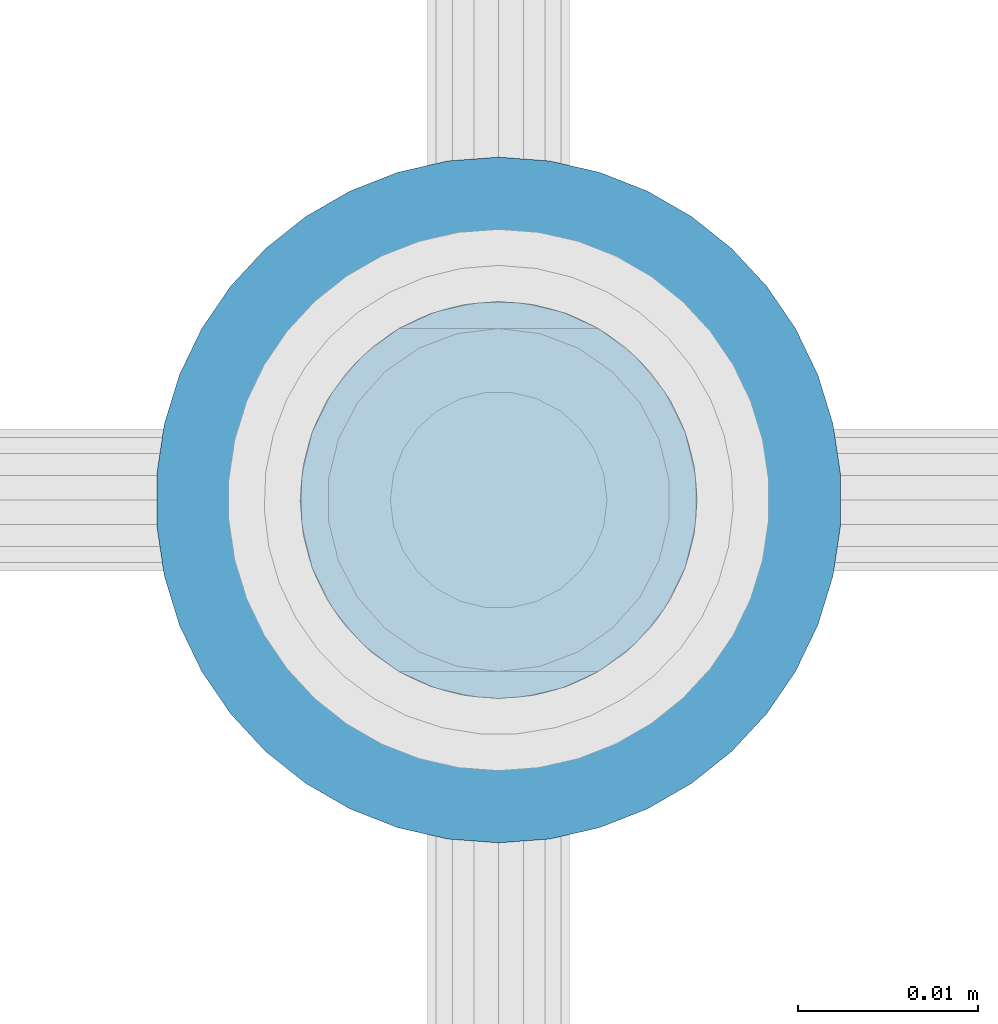
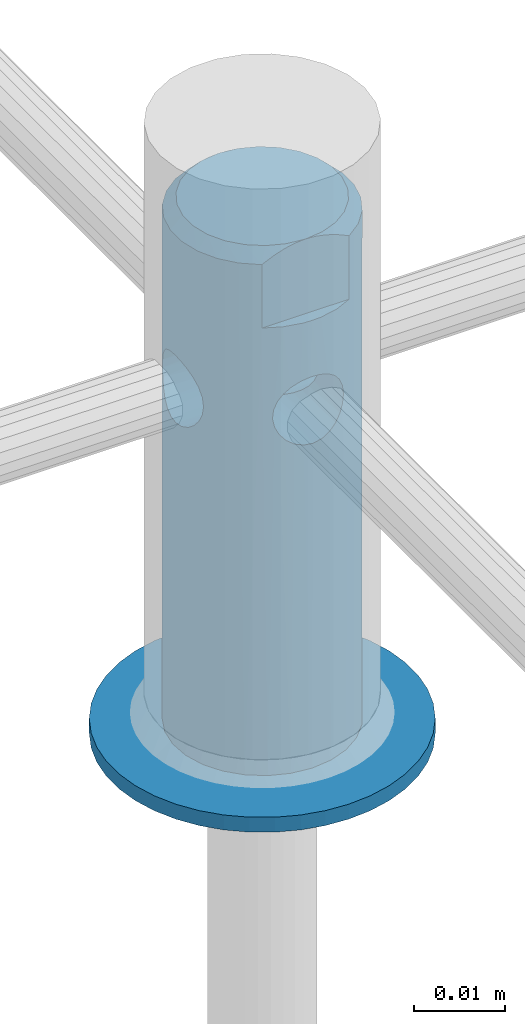
# One storey, part 2 of 3: 2 members.
"""IFC4 building model written with IfcOpenShell, lengths in metres."""

from ifc_helpers import new_model, si_unit, direction, frame, origin_with_axes, place, context, subcontext, project, spatial, triangles, material, element, save


model = new_model("IFC4")

# Units and contexts
model_context = context("Model", 3, precision=1e-05, world=origin_with_axes(), true_north=direction((0.0, 1.0)))
body_context = subcontext(model_context, "Body", "Model", "MODEL_VIEW")
ifc_project = project(units=[si_unit("LENGTHUNIT", "METRE"), si_unit("PLANEANGLEUNIT", "RADIAN"), si_unit("MASSUNIT", "GRAM", prefix="KILO"), si_unit("AREAUNIT", "SQUARE_METRE"), si_unit("TIMEUNIT", "SECOND"), si_unit("VOLUMEUNIT", "CUBIC_METRE")], contexts=[model_context])

# Site, building, storey
site_placement = place(None, origin_with_axes())
site = spatial("IfcSite", under=ifc_project, at=site_placement, CompositionType="ELEMENT")
building_placement = place(site_placement, origin_with_axes())
building = spatial("IfcBuilding", under=site, at=building_placement, CompositionType="ELEMENT")
storey_placement = place(building_placement, origin_with_axes())
storey = spatial("IfcBuildingStorey", under=building, at=storey_placement, Name="Geschoss 1", CompositionType="ELEMENT", Elevation=0.0)

# Members
ifc_material = material()
member_1_placement = place(storey_placement, frame((8.149333, 6.0175, 0.018), z_axis=(0.0, 1.0, 0.0), x_axis=(0.0, 0.0, 1.0)))
element("IfcMember", 1, at=member_1_placement, inside=storey, material=ifc_material, PredefinedType="STUD", context=body_context, shape_type="Tessellation", body=[
    triangles([(0.002, -0.010703, -0.015699), (0.002, -0.008244, -0.017118), (0.002, -0.003688, -0.007658), (0.002, -0.0056, -0.018156), (0.002, -0.001891, -0.008287), (0.002, -0.002832, -0.018788), (0.002, 0.0, -0.0085), (0.002, 0.0, -0.019), (0.002, 0.002832, -0.018788), (0.002, -0.0053, -0.006646), (0.002, -0.012923, -0.013928), (0.002, -0.006646, -0.0053), (0.002, -0.014855, -0.011846), (0.002, -0.016454, -0.0095), (0.002, -0.007658, -0.003688), (0.002, -0.017687, -0.006941), (0.002, -0.008287, -0.001891), (0.002, -0.018524, -0.004228), (0.002, -0.018947, -0.00142), (0.002, -0.0085, 0.0), (0.002, -0.018947, 0.00142), (0.002, -0.008287, 0.001891), (0.002, -0.018524, 0.004228), (0.002, -0.017687, 0.006941), (0.002, -0.007658, 0.003688), (0.002, -0.016454, 0.0095), (0.002, -0.006646, 0.0053), (0.002, -0.014855, 0.011846), (0.002, -0.012923, 0.013928), (0.002, -0.0053, 0.006646), (0.002, -0.010703, 0.015699), (0.002, -0.003688, 0.007658), (0.002, -0.008244, 0.017118), (0.002, -0.0056, 0.018156), (0.002, -0.001891, 0.008287), (0.002, -0.002832, 0.018788), (0.002, 0.0, 0.0085), (0.002, 0.0, 0.019), (0.002, 0.002832, 0.018788), (0.002, 0.001891, 0.008287), (0.002, 0.0056, 0.018156), (0.002, 0.003688, 0.007658), (0.002, 0.008244, 0.017118), (0.002, 0.010703, 0.015699), (0.002, 0.0053, 0.006646), (0.002, 0.012923, 0.013928), (0.002, 0.006646, 0.0053), (0.002, 0.014855, 0.011846), (0.002, 0.016454, 0.0095), (0.002, 0.007658, 0.003688), (0.002, 0.017687, 0.006941), (0.002, 0.008287, 0.001891), (0.002, 0.018524, 0.004228), (0.002, 0.018947, 0.00142), (0.002, 0.0085, 0.0), (0.002, 0.018947, -0.00142), (0.002, 0.008287, -0.001891), (0.002, 0.018524, -0.004228), (0.002, 0.017687, -0.006941), (0.002, 0.007658, -0.003688), (0.002, 0.016454, -0.0095), (0.002, 0.006646, -0.0053), (0.002, 0.014855, -0.011846), (0.002, 0.012923, -0.013928), (0.002, 0.0053, -0.006646), (0.002, 0.010703, -0.015699), (0.002, 0.003688, -0.007658), (0.002, 0.008244, -0.017118), (0.002, 0.0056, -0.018156), (0.002, 0.001891, -0.008287), (0.0, 0.010703, -0.015699), (0.0, 0.008244, -0.017118), (0.0, 0.003688, -0.007658), (0.0, 0.0056, -0.018156), (0.0, 0.001891, -0.008287), (0.0, 0.002832, -0.018788), (0.0, 0.0, -0.0085), (0.0, 0.0, -0.019), (0.0, -0.002832, -0.018788), (0.0, 0.0053, -0.006646), (0.0, 0.012923, -0.013928), (0.0, 0.006646, -0.0053), (0.0, 0.014855, -0.011846), (0.0, 0.016454, -0.0095), (0.0, 0.007658, -0.003688), (0.0, 0.017687, -0.006941), (0.0, 0.008287, -0.001891), (0.0, 0.018524, -0.004228), (0.0, 0.018947, -0.00142), (0.0, 0.0085, 0.0), (0.0, 0.018947, 0.00142), (0.0, 0.008287, 0.001891), (0.0, 0.018524, 0.004228), (0.0, 0.017687, 0.006941), (0.0, 0.007658, 0.003688), (0.0, 0.016454, 0.0095), (0.0, 0.006646, 0.0053), (0.0, 0.014855, 0.011846), (0.0, 0.012923, 0.013928), (0.0, 0.0053, 0.006646), (0.0, 0.010703, 0.015699), (0.0, 0.003688, 0.007658), (0.0, 0.008244, 0.017118), (0.0, 0.0056, 0.018156), (0.0, 0.001891, 0.008287), (0.0, 0.002832, 0.018788), (0.0, 0.0, 0.0085), (0.0, 0.0, 0.019), (0.0, -0.002832, 0.018788), (0.0, -0.001891, 0.008287), (0.0, -0.0056, 0.018156), (0.0, -0.003688, 0.007658), (0.0, -0.008244, 0.017118), (0.0, -0.010703, 0.015699), (0.0, -0.0053, 0.006646), (0.0, -0.012923, 0.013928), (0.0, -0.006646, 0.0053), (0.0, -0.014855, 0.011846), (0.0, -0.016454, 0.0095), (0.0, -0.007658, 0.003688), (0.0, -0.017687, 0.006941), (0.0, -0.008287, 0.001891), (0.0, -0.018524, 0.004228), (0.0, -0.018947, 0.00142), (0.0, -0.0085, 0.0), (0.0, -0.018947, -0.00142), (0.0, -0.008287, -0.001891), (0.0, -0.018524, -0.004228), (0.0, -0.017687, -0.006941), (0.0, -0.007658, -0.003688), (0.0, -0.016454, -0.0095), (0.0, -0.006646, -0.0053), (0.0, -0.014855, -0.011846), (0.0, -0.012923, -0.013928), (0.0, -0.0053, -0.006646), (0.0, -0.010703, -0.015699), (0.0, -0.003688, -0.007658), (0.0, -0.008244, -0.017118), (0.0, -0.0056, -0.018156), (0.0, -0.001891, -0.008287)], [[1, 2, 3], [3, 2, 4], [3, 4, 5], [5, 4, 6], [5, 6, 7], [7, 6, 8], [7, 8, 9], [3, 10, 1], [1, 10, 11], [10, 12, 11], [11, 12, 13], [13, 12, 14], [14, 12, 15], [14, 15, 16], [16, 15, 17], [16, 17, 18], [18, 17, 19], [17, 20, 19], [19, 20, 21], [20, 22, 21], [21, 22, 23], [23, 22, 24], [24, 22, 25], [24, 25, 26], [26, 25, 27], [26, 27, 28], [28, 27, 29], [27, 30, 29], [29, 30, 31], [30, 32, 31], [31, 32, 33], [33, 32, 34], [34, 32, 35], [34, 35, 36], [36, 35, 37], [36, 37, 38], [38, 37, 39], [37, 40, 39], [39, 40, 41], [40, 42, 41], [41, 42, 43], [43, 42, 44], [44, 42, 45], [44, 45, 46], [46, 45, 47], [46, 47, 48], [48, 47, 49], [47, 50, 49], [49, 50, 51], [50, 52, 51], [51, 52, 53], [53, 52, 54], [54, 52, 55], [54, 55, 56], [56, 55, 57], [56, 57, 58], [58, 57, 59], [57, 60, 59], [59, 60, 61], [60, 62, 61], [61, 62, 63], [63, 62, 64], [64, 62, 65], [64, 65, 66], [66, 65, 67], [66, 67, 68], [68, 67, 69], [67, 70, 69], [69, 70, 9], [70, 7, 9], [71, 72, 73], [73, 72, 74], [73, 74, 75], [75, 74, 76], [75, 76, 77], [77, 76, 78], [77, 78, 79], [73, 80, 71], [71, 80, 81], [80, 82, 81], [81, 82, 83], [83, 82, 84], [84, 82, 85], [84, 85, 86], [86, 85, 87], [86, 87, 88], [88, 87, 89], [87, 90, 89], [89, 90, 91], [90, 92, 91], [91, 92, 93], [93, 92, 94], [94, 92, 95], [94, 95, 96], [96, 95, 97], [96, 97, 98], [98, 97, 99], [97, 100, 99], [99, 100, 101], [100, 102, 101], [101, 102, 103], [103, 102, 104], [104, 102, 105], [104, 105, 106], [106, 105, 107], [106, 107, 108], [108, 107, 109], [107, 110, 109], [109, 110, 111], [110, 112, 111], [111, 112, 113], [113, 112, 114], [114, 112, 115], [114, 115, 116], [116, 115, 117], [116, 117, 118], [118, 117, 119], [117, 120, 119], [119, 120, 121], [120, 122, 121], [121, 122, 123], [123, 122, 124], [124, 122, 125], [124, 125, 126], [126, 125, 127], [126, 127, 128], [128, 127, 129], [127, 130, 129], [129, 130, 131], [130, 132, 131], [131, 132, 133], [133, 132, 134], [134, 132, 135], [134, 135, 136], [136, 135, 137], [136, 137, 138], [138, 137, 139], [137, 140, 139], [139, 140, 79], [140, 77, 79], [70, 77, 7], [7, 77, 140], [7, 140, 5], [5, 140, 137], [5, 137, 3], [3, 137, 135], [3, 135, 10], [10, 135, 132], [10, 132, 12], [12, 132, 130], [12, 130, 15], [15, 130, 127], [15, 127, 17], [17, 127, 125], [17, 125, 20], [20, 125, 122], [20, 122, 22], [22, 122, 120], [22, 120, 25], [25, 120, 117], [25, 117, 27], [27, 117, 115], [27, 115, 30], [30, 115, 112], [30, 112, 32], [32, 112, 110], [32, 110, 35], [35, 110, 107], [35, 107, 37], [37, 107, 105], [37, 105, 40], [40, 105, 102], [40, 102, 42], [42, 102, 100], [42, 100, 45], [45, 100, 97], [45, 97, 47], [47, 97, 95], [47, 95, 50], [50, 95, 92], [50, 92, 52], [52, 92, 90], [52, 90, 55], [55, 90, 87], [55, 87, 57], [57, 87, 85], [57, 85, 60], [60, 85, 82], [60, 82, 62], [62, 82, 80], [62, 80, 65], [65, 80, 73], [65, 73, 67], [67, 73, 75], [67, 75, 70], [70, 75, 77], [76, 8, 78], [78, 8, 6], [78, 6, 79], [79, 6, 4], [79, 4, 139], [139, 4, 2], [139, 2, 138], [138, 2, 1], [138, 1, 136], [136, 1, 11], [136, 11, 134], [134, 11, 13], [134, 13, 133], [133, 13, 14], [133, 14, 131], [131, 14, 16], [131, 16, 129], [129, 16, 18], [129, 18, 128], [128, 18, 19], [128, 19, 126], [126, 19, 21], [126, 21, 124], [124, 21, 23], [124, 23, 123], [123, 23, 24], [123, 24, 121], [121, 24, 26], [121, 26, 119], [119, 26, 28], [119, 28, 118], [118, 28, 29], [118, 29, 116], [116, 29, 31], [116, 31, 114], [114, 31, 33], [114, 33, 113], [113, 33, 34], [113, 34, 111], [111, 34, 36], [111, 36, 109], [109, 36, 38], [109, 38, 108], [108, 38, 39], [108, 39, 106], [106, 39, 41], [106, 41, 104], [104, 41, 43], [104, 43, 103], [103, 43, 44], [103, 44, 101], [101, 44, 46], [101, 46, 99], [99, 46, 48], [99, 48, 98], [98, 48, 49], [98, 49, 96], [96, 49, 51], [96, 51, 94], [94, 51, 53], [94, 53, 93], [93, 53, 54], [93, 54, 91], [91, 54, 56], [91, 56, 89], [89, 56, 58], [89, 58, 88], [88, 58, 59], [88, 59, 86], [86, 59, 61], [86, 61, 84], [84, 61, 63], [84, 63, 83], [83, 63, 64], [83, 64, 81], [81, 64, 66], [81, 66, 71], [71, 66, 68], [71, 68, 72], [72, 68, 69], [72, 69, 74], [74, 69, 9], [74, 9, 76], [76, 9, 8]], closed=True),
])
member_2_placement = place(storey_placement, frame((8.149333, 6.0175, 0.02), z_axis=(0.0, 1.0, 0.0), x_axis=(0.0, 0.0, 1.0)))
element("IfcMember", 2, at=member_2_placement, inside=storey, material=ifc_material, PredefinedType="STUD", context=body_context, shape_type="Tessellation", body=[
    triangles([(0.043586, -0.000878, 0.000878), (0.043625, -0.010949, 0.001048), (0.0435, 0.0, 0.0), (0.043501, -0.011, -9.9e-05), (0.043653, -0.001165, -0.001165), (0.043677, -0.010928, -0.001247), (0.044103, -0.00225, -0.00225), (0.044148, -0.010751, -0.002325), (0.044818, -0.003182, -0.003182), (0.044854, -0.010519, -0.003217), (0.04575, -0.003897, -0.003897), (0.045765, -0.010283, -0.003905), (0.046853, -0.010104, -0.00435), (0.043843, -0.001722, 0.001722), (0.044046, -0.010788, 0.002148), (0.044258, -0.0025, 0.0025), (0.044718, -0.01056, 0.003079), (0.044818, -0.003182, 0.003182), (0.0455, -0.003742, 0.003742), (0.045591, -0.010322, 0.0038), (0.046278, -0.004157, 0.004157), (0.046655, -0.010128, 0.004294), (0.047122, -0.004414, 0.004414), (0.047802, -0.01004, 0.004495), (0.048, -0.0045, 0.0045), (0.048587, -0.004462, 0.004462), (0.048947, -0.010083, 0.004398), (0.049165, -0.004347, 0.004347), (0.050055, -0.010246, 0.004003), (0.05025, -0.003897, 0.003897), (0.051004, -0.010477, 0.00335), (0.051182, -0.003182, 0.003182), (0.051743, -0.010713, 0.002497), (0.051897, -0.00225, 0.00225), (0.052278, -0.010911, 0.001395), (0.052347, -0.001165, 0.001165), (0.052495, -0.010998, 0.000198), (0.0525, 0.0, 0.0), (0.052414, -0.000878, -0.000878), (0.052387, -0.010954, -0.000998), (0.052157, -0.001722, -0.001722), (0.051954, -0.010788, -0.002148), (0.051742, -0.0025, -0.0025), (0.051248, -0.01055, -0.003114), (0.051182, -0.003182, -0.003182), (0.0505, -0.003742, -0.003742), (0.050323, -0.010303, -0.003853), (0.049722, -0.004157, -0.004157), (0.049196, -0.010109, -0.004337), (0.048878, -0.004414, -0.004414), (0.048, -0.010037, -0.0045), (0.048, -0.0045, -0.0045), (0.047413, -0.004462, -0.004462), (0.046835, -0.004347, -0.004347), (0.044258, 0.0025, -0.0025), (0.044818, 0.003182, -0.003182), (0.044752, 0.01055, -0.003114), (0.0455, 0.003742, -0.003742), (0.045677, 0.010303, -0.003853), (0.046278, 0.004157, -0.004157), (0.046804, 0.010109, -0.004337), (0.047122, 0.004414, -0.004414), (0.048, 0.010037, -0.0045), (0.048, 0.0045, -0.0045), (0.048587, 0.004462, -0.004462), (0.044046, 0.010788, -0.002148), (0.043843, 0.001722, -0.001722), (0.043613, 0.010954, -0.000998), (0.043586, 0.000878, -0.000878), (0.043505, 0.010998, 0.000198), (0.043653, 0.001165, 0.001165), (0.043722, 0.010911, 0.001395), (0.044103, 0.00225, 0.00225), (0.044257, 0.010713, 0.002497), (0.044818, 0.003182, 0.003182), (0.044996, 0.010477, 0.00335), (0.04575, 0.003897, 0.003897), (0.045945, 0.010246, 0.004003), (0.046835, 0.004347, 0.004347), (0.047053, 0.010083, 0.004398), (0.047413, 0.004462, 0.004462), (0.048198, 0.01004, 0.004495), (0.048, 0.0045, 0.0045), (0.048878, 0.004414, 0.004414), (0.049345, 0.010128, 0.004294), (0.049722, 0.004157, 0.004157), (0.050409, 0.010322, 0.0038), (0.0505, 0.003742, 0.003742), (0.051282, 0.01056, 0.003079), (0.051182, 0.003182, 0.003182), (0.051742, 0.0025, 0.0025), (0.051954, 0.010788, 0.002148), (0.052157, 0.001722, 0.001722), (0.052375, 0.010949, 0.001048), (0.052414, 0.000878, 0.000878), (0.052499, 0.011, -9.9e-05), (0.052347, 0.001165, -0.001165), (0.052323, 0.010928, -0.001247), (0.051897, 0.00225, -0.00225), (0.051852, 0.010751, -0.002325), (0.051182, 0.003182, -0.003182), (0.051146, 0.010519, -0.003217), (0.05025, 0.003897, -0.003897), (0.050235, 0.010283, -0.003905), (0.049147, 0.010104, -0.00435), (0.049165, 0.004347, -0.004347), (0.046804, 0.004337, 0.010109), (0.045677, 0.003853, 0.010303), (0.044752, 0.003114, 0.01055), (0.044046, 0.002148, 0.010788), (0.043613, 0.000998, 0.010954), (0.043505, -0.000198, 0.010998), (0.043722, -0.001395, 0.010911), (0.044257, -0.002497, 0.010713), (0.048, 0.0045, 0.010037), (0.049147, 0.00435, 0.010104), (0.050235, 0.003905, 0.010283), (0.051146, 0.003217, 0.010519), (0.051852, 0.002325, 0.010751), (0.052323, 0.001247, 0.010928), (0.052499, 9.9e-05, 0.011), (0.052375, -0.001048, 0.010949), (0.051954, -0.002148, 0.010788), (0.051282, -0.003079, 0.01056), (0.050409, -0.0038, 0.010322), (0.049345, -0.004294, 0.010128), (0.048198, -0.004495, 0.01004), (0.047053, -0.004398, 0.010083), (0.045945, -0.004003, 0.010246), (0.044996, -0.00335, 0.010477), (0.049196, 0.004337, -0.010109), (0.048, 0.0045, -0.010037), (0.050323, 0.003853, -0.010303), (0.051248, 0.003114, -0.01055), (0.051954, 0.002148, -0.010788), (0.052387, 0.000998, -0.010954), (0.052495, -0.000198, -0.010998), (0.052278, -0.001395, -0.010911), (0.051743, -0.002497, -0.010713), (0.051004, -0.00335, -0.010477), (0.050055, -0.004003, -0.010246), (0.048947, -0.004398, -0.010083), (0.047802, -0.004495, -0.01004), (0.046655, -0.004294, -0.010128), (0.045591, -0.0038, -0.010322), (0.044718, -0.003079, -0.01056), (0.044046, -0.002148, -0.010788), (0.043625, -0.001048, -0.010949), (0.043501, 9.9e-05, -0.011), (0.043677, 0.001247, -0.010928), (0.044148, 0.002325, -0.010751), (0.044854, 0.003217, -0.010519), (0.045765, 0.003905, -0.010283), (0.046853, 0.00435, -0.010104), (0.06, -0.005545, -0.0095), (0.06, -0.003429, -0.010452), (0.06, 0.005545, -0.0095), (0.06, -0.00116, -0.010939), (0.06, 0.0, -0.011), (0.06, 0.00116, -0.010939), (0.06, 0.003429, -0.010452), (0.07, 0.0, -0.0095), (0.069913, 0.001291, -0.0095), (0.07, 0.002273, -0.009224), (0.069646, 0.002618, -0.0095), (0.07, 0.004415, -0.008412), (0.069184, 0.00402, -0.0095), (0.0685, 0.005545, -0.0095), (0.07, 0.0063, -0.007111), (0.0685, 0.007578, -0.007973), (0.07, 0.007818, -0.005397), (0.0685, 0.009206, -0.00602), (0.07, 0.008883, -0.003369), (0.0685, 0.010343, -0.003746), (0.07, 0.009431, -0.001145), (0.0685, 0.010926, -0.001271), (0.0685, 0.010926, 0.001271), (0.07, 0.009431, 0.001145), (0.0685, 0.010343, 0.003746), (0.07, 0.008883, 0.003369), (0.0685, 0.009206, 0.00602), (0.07, 0.007818, 0.005397), (0.0685, 0.007578, 0.007973), (0.07, 0.0063, 0.007111), (0.0685, 0.005545, 0.0095), (0.07, 0.004415, 0.008412), (0.069184, 0.00402, 0.0095), (0.069646, 0.002618, 0.0095), (0.07, 0.002273, 0.009224), (0.069913, 0.001291, 0.0095), (0.07, 0.0, 0.0095), (0.06, 0.003429, 0.010452), (0.06, 0.00116, 0.010939), (0.06, 0.005545, 0.0095), (0.06, -0.00116, 0.010939), (0.06, -0.003429, 0.010452), (0.06, -0.005545, 0.0095), (0.0685, -0.005545, 0.0095), (0.069184, -0.00402, 0.0095), (0.069646, -0.002618, 0.0095), (0.069913, -0.001291, 0.0095), (0.069184, -0.00402, -0.0095), (0.07, -0.004415, -0.008412), (0.0685, -0.005545, -0.0095), (0.07, -0.0063, -0.007111), (0.0685, -0.007578, -0.007973), (0.07, -0.007818, -0.005397), (0.0685, -0.009206, -0.00602), (0.07, -0.008883, -0.003369), (0.0685, -0.010343, -0.003746), (0.07, -0.009431, -0.001145), (0.0685, -0.010926, -0.001271), (0.07, -0.009431, 0.001145), (0.0685, -0.010926, 0.001271), (0.0685, -0.010343, 0.003746), (0.069646, -0.002618, -0.0095), (0.07, -0.002273, -0.009224), (0.069913, -0.001291, -0.0095), (0.07, -0.008883, 0.003369), (0.0685, -0.009206, 0.00602), (0.07, -0.007818, 0.005397), (0.0685, -0.007578, 0.007973), (0.07, -0.0063, 0.007111), (0.07, -0.004415, 0.008412), (0.07, -0.002273, 0.009224), (0.028, -0.005706, -0.001854), (0.028, -0.005706, 0.001854), (0.028, -0.004854, -0.003527), (0.028, -0.004854, 0.003527), (0.028, -0.003527, -0.004854), (0.028, -0.003527, 0.004854), (0.028, -0.001854, -0.005706), (0.028, -0.001854, 0.005706), (0.028, 0.0, -0.006), (0.028, 0.0, 0.006), (0.028, 0.001854, -0.005706), (0.028, 0.001854, 0.005706), (0.028, 0.003527, -0.004854), (0.028, 0.003527, 0.004854), (0.028, 0.004854, -0.003527), (0.028, 0.004854, 0.003527), (0.028, 0.005706, -0.001854), (0.028, 0.005706, 0.001854), (0.028, 0.006, 0.0), (0.028, -0.006, 0.0), (0.0, 0.002537, -0.010703), (0.0, 0.0, -0.011), (0.0, 0.004937, -0.00983), (0.0, 0.007071, -0.008426), (0.0, 0.008823, -0.006569), (0.0, 0.0101, -0.004357), (0.0, 0.010833, -0.00191), (0.0, 0.010981, 0.00064), (0.0, 0.010538, 0.003155), (0.0, 0.009526, 0.0055), (0.0, 0.008001, 0.007549), (0.0, 0.006045, 0.00919), (0.0, 0.003762, 0.010337), (0.0, 0.001277, 0.010926), (0.0, -0.001277, 0.010926), (0.0, -0.003762, 0.010337), (0.0, -0.006045, 0.00919), (0.0, -0.008001, 0.007549), (0.0, -0.009526, 0.0055), (0.0, -0.010538, 0.003155), (0.0, -0.010981, 0.00064), (0.0, -0.010833, -0.00191), (0.0, -0.0101, -0.004357), (0.0, -0.008823, -0.006569), (0.0, -0.007071, -0.008426), (0.0, -0.004937, -0.00983), (0.0, -0.002537, -0.010703), (0.0, -0.001854, -0.005706), (0.0, 0.0, -0.006), (0.0, 0.001854, -0.005706), (0.0, 0.003527, -0.004854), (0.0, 0.004854, -0.003527), (0.0, 0.005706, -0.001854), (0.0, 0.006, 0.0), (0.0, 0.005706, 0.001854), (0.0, 0.004854, 0.003527), (0.0, 0.003527, 0.004854), (0.0, 0.001854, 0.005706), (0.0, 0.0, 0.006), (0.0, -0.001854, 0.005706), (0.0, -0.003527, 0.004854), (0.0, -0.004854, 0.003527), (0.0, -0.005706, 0.001854), (0.0, -0.006, 0.0), (0.0, -0.005706, -0.001854), (0.0, -0.004854, -0.003527), (0.0, -0.003527, -0.004854)], [[1, 2, 3], [3, 2, 4], [3, 4, 5], [5, 4, 6], [5, 6, 7], [7, 6, 8], [7, 8, 9], [9, 8, 10], [9, 10, 11], [11, 10, 12], [11, 12, 13], [1, 14, 2], [2, 14, 15], [14, 16, 15], [15, 16, 17], [16, 18, 17], [17, 18, 19], [17, 19, 20], [20, 19, 21], [20, 21, 22], [22, 21, 23], [22, 23, 24], [24, 23, 25], [24, 25, 26], [24, 26, 27], [27, 26, 28], [27, 28, 29], [29, 28, 30], [29, 30, 31], [31, 30, 32], [31, 32, 33], [33, 32, 34], [33, 34, 35], [35, 34, 36], [35, 36, 37], [37, 36, 38], [37, 38, 39], [37, 39, 40], [40, 39, 41], [40, 41, 42], [42, 41, 43], [42, 43, 44], [44, 43, 45], [44, 45, 46], [44, 46, 47], [47, 46, 48], [47, 48, 49], [49, 48, 50], [49, 50, 51], [51, 50, 52], [51, 52, 53], [51, 53, 13], [13, 53, 54], [13, 54, 11], [55, 56, 57], [57, 56, 58], [57, 58, 59], [59, 58, 60], [59, 60, 61], [61, 60, 62], [61, 62, 63], [63, 62, 64], [63, 64, 65], [57, 66, 55], [55, 66, 67], [66, 68, 67], [67, 68, 69], [68, 70, 69], [69, 70, 3], [3, 70, 71], [71, 70, 72], [71, 72, 73], [73, 72, 74], [73, 74, 75], [75, 74, 76], [75, 76, 77], [77, 76, 78], [77, 78, 79], [79, 78, 80], [79, 80, 81], [81, 80, 82], [81, 82, 83], [83, 82, 84], [82, 85, 84], [84, 85, 86], [85, 87, 86], [86, 87, 88], [87, 89, 88], [88, 89, 90], [90, 89, 91], [91, 89, 92], [91, 92, 93], [93, 92, 94], [93, 94, 95], [95, 94, 96], [95, 96, 38], [38, 96, 97], [96, 98, 97], [97, 98, 99], [98, 100, 99], [99, 100, 101], [100, 102, 101], [101, 102, 103], [102, 104, 103], [103, 104, 105], [103, 105, 106], [106, 105, 65], [105, 63, 65], [79, 107, 77], [77, 107, 108], [77, 108, 75], [75, 108, 109], [75, 109, 73], [73, 109, 110], [73, 110, 71], [71, 110, 111], [71, 111, 3], [3, 111, 112], [3, 112, 1], [1, 112, 113], [1, 113, 14], [14, 113, 114], [14, 114, 16], [16, 114, 18], [79, 81, 107], [107, 81, 115], [81, 83, 115], [115, 83, 84], [115, 84, 116], [116, 84, 86], [116, 86, 117], [117, 86, 88], [117, 88, 118], [118, 88, 90], [118, 90, 91], [118, 91, 119], [119, 91, 93], [119, 93, 120], [120, 93, 95], [120, 95, 121], [121, 95, 38], [121, 38, 122], [122, 38, 36], [122, 36, 123], [123, 36, 34], [123, 34, 124], [124, 34, 32], [124, 32, 125], [125, 32, 30], [125, 30, 126], [126, 30, 28], [126, 28, 26], [126, 26, 127], [127, 26, 25], [127, 25, 128], [128, 25, 23], [128, 23, 21], [128, 21, 129], [129, 21, 19], [129, 19, 130], [130, 19, 18], [130, 18, 114], [103, 106, 131], [131, 106, 65], [131, 65, 132], [132, 65, 64], [132, 64, 62], [131, 133, 103], [103, 133, 101], [133, 134, 101], [101, 134, 99], [134, 135, 99], [99, 135, 97], [135, 136, 97], [97, 136, 38], [136, 137, 38], [38, 137, 39], [137, 138, 39], [39, 138, 41], [138, 139, 41], [41, 139, 43], [43, 139, 45], [45, 139, 140], [45, 140, 46], [46, 140, 141], [46, 141, 48], [48, 141, 142], [48, 142, 50], [50, 142, 52], [142, 143, 52], [52, 143, 53], [143, 144, 53], [53, 144, 54], [54, 144, 11], [11, 144, 145], [11, 145, 9], [9, 145, 146], [9, 146, 7], [7, 146, 147], [7, 147, 5], [5, 147, 148], [5, 148, 3], [3, 148, 149], [3, 149, 69], [69, 149, 150], [69, 150, 67], [67, 150, 151], [67, 151, 55], [55, 151, 152], [55, 152, 56], [56, 152, 58], [152, 153, 58], [58, 153, 60], [153, 154, 60], [60, 154, 62], [154, 132, 62], [155, 156, 157], [157, 156, 158], [157, 158, 159], [159, 160, 157], [157, 160, 161], [162, 163, 164], [164, 163, 165], [164, 165, 166], [166, 165, 167], [166, 167, 168], [166, 168, 169], [169, 168, 170], [169, 170, 171], [171, 170, 172], [171, 172, 173], [173, 172, 174], [173, 174, 175], [175, 174, 176], [175, 176, 177], [175, 177, 178], [178, 177, 179], [178, 179, 180], [180, 179, 181], [180, 181, 182], [182, 181, 183], [182, 183, 184], [184, 183, 185], [184, 185, 186], [186, 185, 187], [186, 187, 188], [186, 188, 189], [189, 188, 190], [189, 190, 191], [192, 193, 194], [194, 193, 195], [194, 195, 196], [196, 197, 194], [198, 199, 197], [197, 199, 200], [197, 200, 201], [201, 191, 197], [197, 191, 194], [191, 190, 194], [194, 190, 188], [194, 188, 187], [187, 185, 194], [202, 203, 204], [204, 203, 205], [204, 205, 206], [206, 205, 207], [206, 207, 208], [208, 207, 209], [208, 209, 210], [210, 209, 211], [210, 211, 212], [212, 211, 213], [212, 213, 214], [214, 213, 215], [202, 216, 203], [203, 216, 217], [216, 218, 217], [217, 218, 162], [213, 219, 215], [215, 219, 220], [219, 221, 220], [220, 221, 222], [221, 223, 222], [222, 223, 198], [223, 224, 198], [198, 224, 199], [199, 224, 200], [200, 224, 225], [200, 225, 201], [201, 225, 191], [204, 155, 202], [202, 155, 216], [165, 163, 157], [157, 163, 162], [157, 162, 155], [155, 162, 218], [155, 218, 216], [168, 167, 157], [157, 167, 165], [226, 227, 228], [228, 227, 229], [228, 229, 230], [230, 229, 231], [230, 231, 232], [232, 231, 233], [232, 233, 234], [234, 233, 235], [234, 235, 236], [236, 235, 237], [236, 237, 238], [238, 237, 239], [238, 239, 240], [240, 239, 241], [240, 241, 242], [242, 241, 243], [242, 243, 244], [226, 245, 227], [152, 151, 246], [246, 151, 150], [246, 150, 247], [247, 150, 149], [247, 149, 148], [152, 246, 153], [153, 246, 248], [153, 248, 154], [154, 248, 132], [132, 248, 157], [157, 248, 249], [157, 249, 170], [170, 249, 250], [170, 250, 172], [172, 250, 63], [172, 63, 174], [174, 63, 105], [174, 105, 104], [250, 251, 63], [63, 251, 61], [68, 66, 252], [252, 66, 57], [252, 57, 251], [251, 57, 59], [251, 59, 61], [252, 253, 68], [68, 253, 70], [70, 253, 72], [72, 253, 254], [72, 254, 74], [74, 254, 76], [181, 82, 255], [255, 82, 80], [255, 80, 254], [254, 80, 78], [254, 78, 76], [255, 256, 181], [181, 256, 183], [256, 257, 183], [183, 257, 194], [183, 194, 185], [194, 257, 115], [115, 257, 258], [115, 258, 107], [107, 258, 108], [112, 111, 259], [259, 111, 110], [259, 110, 258], [258, 110, 109], [258, 109, 108], [259, 260, 112], [112, 260, 113], [113, 260, 114], [114, 260, 261], [114, 261, 130], [130, 261, 129], [222, 197, 262], [262, 197, 127], [262, 127, 261], [261, 127, 128], [261, 128, 129], [262, 263, 222], [222, 263, 220], [263, 264, 220], [220, 264, 24], [220, 24, 215], [215, 24, 27], [215, 27, 29], [24, 264, 22], [22, 264, 265], [22, 265, 20], [20, 265, 17], [17, 265, 15], [15, 265, 266], [15, 266, 2], [2, 266, 4], [266, 267, 4], [4, 267, 6], [13, 12, 268], [268, 12, 10], [268, 10, 267], [267, 10, 8], [267, 8, 6], [13, 268, 51], [51, 268, 269], [51, 269, 208], [208, 269, 206], [269, 270, 206], [206, 270, 155], [206, 155, 204], [270, 271, 155], [155, 271, 143], [155, 143, 142], [147, 146, 272], [272, 146, 145], [272, 145, 271], [271, 145, 144], [271, 144, 143], [147, 272, 148], [148, 272, 247], [208, 210, 51], [51, 210, 49], [37, 40, 212], [212, 40, 42], [212, 42, 210], [210, 42, 44], [210, 44, 47], [212, 214, 37], [37, 214, 35], [35, 214, 33], [33, 214, 215], [33, 215, 31], [31, 215, 29], [222, 198, 197], [127, 197, 126], [126, 197, 196], [126, 196, 125], [125, 196, 124], [124, 196, 123], [123, 196, 195], [123, 195, 122], [122, 195, 121], [195, 193, 121], [121, 193, 120], [120, 193, 119], [119, 193, 192], [119, 192, 118], [118, 192, 117], [117, 192, 116], [116, 192, 194], [116, 194, 115], [181, 179, 82], [82, 179, 85], [96, 94, 177], [177, 94, 92], [177, 92, 179], [179, 92, 89], [179, 89, 87], [177, 176, 96], [96, 176, 98], [98, 176, 100], [100, 176, 174], [100, 174, 102], [102, 174, 104], [170, 168, 157], [132, 157, 131], [131, 157, 161], [131, 161, 133], [133, 161, 134], [134, 161, 135], [135, 161, 160], [135, 160, 136], [136, 160, 159], [136, 159, 137], [137, 159, 158], [137, 158, 138], [138, 158, 139], [158, 156, 139], [139, 156, 140], [155, 142, 156], [156, 142, 141], [156, 141, 140], [87, 85, 179], [47, 49, 210], [273, 234, 274], [274, 234, 236], [274, 236, 275], [275, 236, 238], [275, 238, 276], [276, 238, 240], [276, 240, 277], [277, 240, 242], [277, 242, 278], [278, 242, 244], [278, 244, 279], [279, 244, 243], [279, 243, 280], [280, 243, 241], [280, 241, 281], [281, 241, 239], [281, 239, 282], [282, 239, 237], [282, 237, 283], [283, 237, 235], [283, 235, 284], [284, 235, 233], [284, 233, 285], [285, 233, 231], [285, 231, 286], [286, 231, 229], [286, 229, 287], [287, 229, 227], [287, 227, 288], [288, 227, 245], [288, 245, 289], [289, 245, 226], [289, 226, 290], [290, 226, 228], [290, 228, 291], [291, 228, 230], [291, 230, 292], [292, 230, 232], [292, 232, 273], [273, 232, 234], [251, 250, 277], [277, 250, 249], [277, 249, 276], [276, 249, 248], [276, 248, 275], [275, 248, 246], [275, 246, 274], [274, 246, 247], [274, 247, 272], [277, 278, 251], [251, 278, 252], [278, 279, 252], [252, 279, 253], [279, 280, 253], [253, 280, 254], [254, 280, 255], [255, 280, 281], [255, 281, 256], [256, 281, 282], [256, 282, 257], [257, 282, 283], [257, 283, 258], [258, 283, 259], [283, 284, 259], [259, 284, 260], [284, 285, 260], [260, 285, 261], [261, 285, 262], [262, 285, 286], [262, 286, 263], [263, 286, 287], [263, 287, 264], [264, 287, 288], [264, 288, 265], [265, 288, 266], [288, 289, 266], [266, 289, 267], [289, 290, 267], [267, 290, 268], [290, 291, 268], [268, 291, 269], [269, 291, 270], [270, 291, 292], [270, 292, 271], [271, 292, 273], [271, 273, 272], [272, 273, 274], [175, 178, 173], [173, 178, 180], [173, 180, 171], [171, 180, 182], [171, 182, 169], [169, 182, 184], [169, 184, 166], [166, 184, 186], [166, 186, 164], [164, 186, 189], [164, 189, 162], [162, 189, 191], [162, 191, 217], [217, 191, 225], [217, 225, 203], [203, 225, 224], [203, 224, 205], [205, 224, 223], [205, 223, 207], [207, 223, 221], [207, 221, 209], [209, 221, 219], [209, 219, 211], [211, 219, 213]], closed=True),
])

save(model, "model.ifc")
